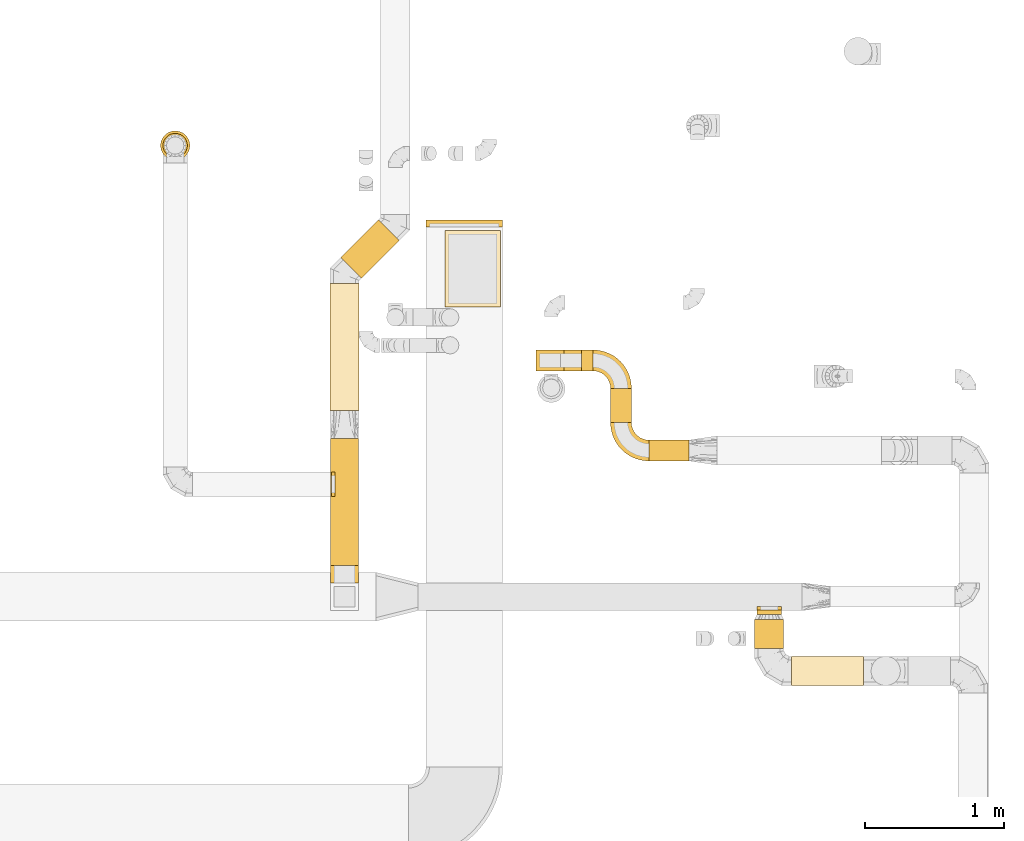
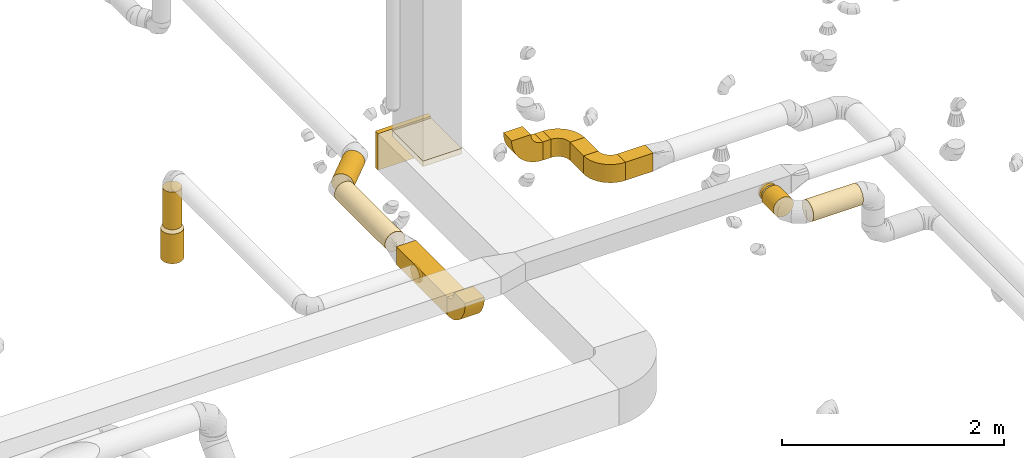
# One storey, part 9 of 97: 19 coverings.
"""IFC2X3 building model written with IfcOpenShell, lengths in millimetres."""

from ifc_helpers import new_model, entity, si_unit, converted_unit, derived_unit, direction, frame, frame_2d, origin, origin_2d_with_axis, place, context, subcontext, project, spatial, polyline, circle_curve, parameter, trimmed, segment, composite_curve, rectangle, circle, outline, extrude, element, save


model = new_model("IFC2X3")

# Units and contexts
model_context = context("Model", 3, precision=0.01, world=origin(), true_north=direction((6.12303176911189e-17, 1.0)))
body_context = subcontext(model_context, "Body", "Model", "MODEL_VIEW")
ifc_project = project(units=[si_unit("LENGTHUNIT", "METRE", prefix="MILLI"), si_unit("AREAUNIT", "SQUARE_METRE"), si_unit("VOLUMEUNIT", "CUBIC_METRE"), converted_unit("PLANEANGLEUNIT", "DEGREE", entity("IfcRatioMeasure", 0.0174532925199433), si_unit("PLANEANGLEUNIT", "RADIAN"), dimensions=[0, 0, 0, 0, 0, 0, 0]), si_unit("MASSUNIT", "GRAM", prefix="KILO"), derived_unit("MASSDENSITYUNIT", [(si_unit("MASSUNIT", "GRAM", prefix="KILO"), 1), (si_unit("LENGTHUNIT", "METRE"), -3)]), derived_unit("MOMENTOFINERTIAUNIT", [(si_unit("LENGTHUNIT", "METRE"), 4)]), si_unit("TIMEUNIT", "SECOND"), si_unit("FREQUENCYUNIT", "HERTZ"), si_unit("THERMODYNAMICTEMPERATUREUNIT", "DEGREE_CELSIUS"), derived_unit("THERMALTRANSMITTANCEUNIT", [(si_unit("MASSUNIT", "GRAM", prefix="KILO"), 1), (si_unit("THERMODYNAMICTEMPERATUREUNIT", "KELVIN"), -1), (si_unit("TIMEUNIT", "SECOND"), -3)]), derived_unit("VOLUMETRICFLOWRATEUNIT", [(si_unit("LENGTHUNIT", "METRE"), 3), (si_unit("TIMEUNIT", "SECOND"), -1)]), derived_unit("MASSFLOWRATEUNIT", [(si_unit("MASSUNIT", "GRAM", prefix="KILO"), 1), (si_unit("TIMEUNIT", "SECOND"), -1)]), derived_unit("ROTATIONALFREQUENCYUNIT", [(si_unit("TIMEUNIT", "SECOND"), -1)]), si_unit("ELECTRICCURRENTUNIT", "AMPERE"), si_unit("ELECTRICVOLTAGEUNIT", "VOLT"), si_unit("POWERUNIT", "WATT"), si_unit("FORCEUNIT", "NEWTON", prefix="KILO"), si_unit("ILLUMINANCEUNIT", "LUX"), si_unit("LUMINOUSFLUXUNIT", "LUMEN"), si_unit("LUMINOUSINTENSITYUNIT", "CANDELA"), derived_unit("USERDEFINED", [(si_unit("MASSUNIT", "GRAM", prefix="KILO"), -1), (si_unit("LENGTHUNIT", "METRE"), -2), (si_unit("TIMEUNIT", "SECOND"), 3), (si_unit("LUMINOUSFLUXUNIT", "LUMEN"), 1)]), derived_unit("LINEARVELOCITYUNIT", [(si_unit("LENGTHUNIT", "METRE"), 1), (si_unit("TIMEUNIT", "SECOND"), -1)]), si_unit("PRESSUREUNIT", "PASCAL"), derived_unit("USERDEFINED", [(si_unit("LENGTHUNIT", "METRE"), -2), (si_unit("MASSUNIT", "GRAM", prefix="KILO"), 1), (si_unit("TIMEUNIT", "SECOND"), -2)]), derived_unit("LINEARFORCEUNIT", [(si_unit("MASSUNIT", "GRAM", prefix="KILO"), 1), (si_unit("LENGTHUNIT", "METRE"), 1), (si_unit("TIMEUNIT", "SECOND"), -2), (si_unit("LENGTHUNIT", "METRE"), -1)]), derived_unit("PLANARFORCEUNIT", [(si_unit("MASSUNIT", "GRAM", prefix="KILO"), 1), (si_unit("LENGTHUNIT", "METRE"), 1), (si_unit("TIMEUNIT", "SECOND"), -2), (si_unit("LENGTHUNIT", "METRE"), -2)])], contexts=[model_context])

# Site, building, storey
site_placement = place(None, origin())
site = spatial("IfcSite", under=ifc_project, at=site_placement, CompositionType="ELEMENT")
building_placement = place(site_placement, origin())
building = spatial("IfcBuilding", under=site, at=building_placement, CompositionType="ELEMENT")
storey_placement = place(building_placement, frame((0.0, 0.0, -4900.0)))
storey = spatial("IfcBuildingStorey", under=building, at=storey_placement, CompositionType="ELEMENT", Elevation=-4900.0)

# Coverings
covering_1_placement = place(storey_placement, frame((67714.12, 12828.08, 3780.0)))
element("IfcCovering", 1, at=covering_1_placement, inside=storey, PredefinedType="INSULATION", context=body_context, shape_type="SweptSolid", body=[
    extrude(rectangle(XDim=50.0000000000016, YDim=549.999999999996, at=origin_2d_with_axis()), frame((275.0, 25.0, 0.0), z_axis=(0.0, 0.0, 1.0), x_axis=(0.0, -1.0, 0.0)), (0.0, 0.0, 1.0), 400.0),
])
covering_2_placement = place(storey_placement, frame((67849.81, 12253.05, 4119.01)))
element("IfcCovering", 2, at=covering_2_placement, inside=storey, PredefinedType="INSULATION", context=body_context, shape_type="SweptSolid", body=[
    extrude(rectangle(XDim=399.999999999996, YDim=550.000000000001, at=origin_2d_with_axis()), frame((200.0, 275.0, 0.0)), (0.0, 0.0, 1.0), 60.8775885811206),
])
covering_3_placement = place(storey_placement, frame((70088.14, 10045.77, 4260.9)))
element("IfcCovering", 3, at=covering_3_placement, inside=storey, PredefinedType="INSULATION", context=body_context, shape_type="SweptSolid", body=[
    extrude(circle(Radius=87.5, at=origin_2d_with_axis()), frame((89.1, 0.0, 89.1), z_axis=(0.0, 1.0, 0.0), x_axis=(-1.0, 0.0, 0.0)), (0.0, 0.0, 1.0), 33.2897157502389),
])
covering_4_placement = place(storey_placement, frame((70088.14, 10079.06, 4260.9)))
element("IfcCovering", 4, at=covering_4_placement, inside=storey, PredefinedType="INSULATION", context=body_context, shape_type="SweptSolid", body=[
    extrude(circle(Radius=87.5, at=origin_2d_with_axis()), frame((89.1, 0.0, 89.1), z_axis=(0.0, 1.0, 0.0), x_axis=(1.0, 0.0, 0.0)), (0.0, 0.0, 1.0), 26.0960000000116),
])
covering_5_placement = place(storey_placement, frame((70070.64, 9801.0, 4243.4)))
element("IfcCovering", 5, at=covering_5_placement, inside=storey, PredefinedType="INSULATION", context=body_context, shape_type="SweptSolid", body=[
    extrude(circle(Radius=105.0, at=origin_2d_with_axis()), frame((106.6, 0.0, 106.6), z_axis=(0.0, 1.0, 0.0), x_axis=(1.0, 0.0, 0.0)), (0.0, 0.0, 1.0), 209.769824249999),
])
covering_6_placement = place(storey_placement, frame((70337.23, 9534.41, 4243.4)))
element("IfcCovering", 6, at=covering_6_placement, inside=storey, PredefinedType="INSULATION", context=body_context, shape_type="SweptSolid", body=[
    extrude(circle(Radius=105.0, at=origin_2d_with_axis()), frame((0.0, 106.6, 106.6), z_axis=(1.0, 0.0, 0.0), x_axis=(0.0, 1.0, 0.0)), (0.0, 0.0, 1.0), 517.221330000017),
])
covering_7_placement = place(storey_placement, frame((67029.73, 10399.06, 3900.0)))
element("IfcCovering", 7, at=covering_7_placement, inside=storey, PredefinedType="INSULATION", context=body_context, shape_type="SweptSolid", body=[
    extrude(rectangle(XDim=912.000000000007, YDim=200.000000000007, at=origin_2d_with_axis()), frame((100.0, 456.0, 0.0), z_axis=(0.0, 0.0, 1.0), x_axis=(0.0, 1.0, 0.0)), (0.0, 0.0, 1.0), 200.0),
])
covering_8_placement = place(storey_placement, frame((67023.13, 11511.06, 3893.4)))
element("IfcCovering", 8, at=covering_8_placement, inside=storey, PredefinedType="INSULATION", context=body_context, shape_type="SweptSolid", body=[
    extrude(circle(Radius=105.0, at=origin_2d_with_axis()), frame((106.6, 0.0, 106.6), z_axis=(0.0, 1.0, 0.0), x_axis=(-1.0, 0.0, 0.0)), (0.0, 0.0, 1.0), 909.725830020307),
])
covering_9_placement = place(storey_placement, frame((67100.75, 12458.09, 3893.4)))
element("IfcCovering", 9, at=covering_9_placement, inside=storey, PredefinedType="INSULATION", context=body_context, shape_type="SweptSolid", body=[
    extrude(circle(Radius=105.0, at=origin_2d_with_axis()), frame((75.84, 75.84, 106.6), z_axis=(0.707106781186562, 0.707106781186533, 0.0), x_axis=(-0.707106781186533, 0.707106781186562, 0.0)), (0.0, 0.0, 1.0), 382.900697862583),
])
covering_10_placement = place(storey_placement, frame((67034.73, 10891.13, 3910.9)))
element("IfcCovering", 10, at=covering_10_placement, inside=storey, PredefinedType="INSULATION", context=body_context, shape_type="SweptSolid", body=[
    extrude(circle(Radius=87.5, at=origin_2d_with_axis()), frame((0.0, 89.1, 89.1), z_axis=(1.0, 0.0, 0.0), x_axis=(0.0, -1.0, 0.0)), (0.0, 0.0, 1.0), 26.0960000000159),
])
covering_11_placement = place(storey_placement, frame((65807.34, 13306.21, 3100.11)))
element("IfcCovering", 11, at=covering_11_placement, inside=storey, PredefinedType="INSULATION", context=body_context, shape_type="SweptSolid", body=[
    extrude(circle(Radius=105.0, at=origin_2d_with_axis()), frame((106.6, 106.6, 0.0), z_axis=(0.0, 0.0, 1.0), x_axis=(-1.0, 0.0, 0.0)), (0.0, 0.0, 1.0), 326.124652279636),
])
covering_12_placement = place(storey_placement, frame((65824.84, 13323.71, 3461.23)))
element("IfcCovering", 12, at=covering_12_placement, inside=storey, PredefinedType="INSULATION", context=body_context, shape_type="SweptSolid", body=[
    extrude(circle(Radius=87.5, at=origin_2d_with_axis()), frame((89.1, 89.1, 0.0), z_axis=(0.0, 0.0, 1.0), x_axis=(-1.0, 0.0, 0.0)), (0.0, 0.0, 1.0), 413.765350053108),
])
covering_13_placement = place(storey_placement, frame((69039.1, 11423.58, 4125.0)))
element("IfcCovering", 13, at=covering_13_placement, inside=storey, PredefinedType="INSULATION", context=body_context, shape_type="SweptSolid", body=[
    extrude(rectangle(XDim=246.447609999898, YDim=150.000000000001, at=origin_2d_with_axis()), frame((75.0, 123.22, 0.0), z_axis=(0.0, 0.0, 1.0), x_axis=(0.0, -1.0, 0.0)), (0.0, 0.0, 1.0), 200.0),
])
covering_14_placement = place(storey_placement, frame((68829.23, 11795.03, 4125.0)))
element("IfcCovering", 14, at=covering_14_placement, inside=storey, PredefinedType="INSULATION", context=body_context, shape_type="SweptSolid", body=[
    extrude(rectangle(XDim=84.8741199999927, YDim=150.000000000001, at=origin_2d_with_axis()), frame((42.44, 75.0, 0.0), z_axis=(0.0, 0.0, 1.0), x_axis=(-1.0, 0.0, 0.0)), (0.0, 0.0, 1.0), 200.0),
])
covering_15_placement = place(storey_placement, frame((69314.1, 11148.58, 4125.0)))
element("IfcCovering", 15, at=covering_15_placement, inside=storey, PredefinedType="INSULATION", context=body_context, shape_type="SweptSolid", body=[
    extrude(rectangle(XDim=287.766589999998, YDim=150.000000000001, at=origin_2d_with_axis()), frame((143.88, 75.0, 0.0)), (0.0, 0.0, 1.0), 200.0),
])
covering_16_placement = place(storey_placement, frame((67029.73, 10072.47, 3898.4)))
element("IfcCovering", 16, at=covering_16_placement, inside=storey, PredefinedType="INSULATION", context=body_context, shape_type="SweptSolid", body=[
    extrude(outline(composite_curve([segment(polyline([(12.5, -112.5), (212.5, -112.5)]), True, "CONTINUOUS"), segment(trimmed(circle_curve(frame_2d((-112.5, -112.5), x_axis=(0.0, 1.0)), 325.0), [parameter(270.0)], [parameter(0.0)], True, "PARAMETER"), True, "CONTINUOUS"), segment(polyline([(-112.5, 212.5), (-112.5, 12.5)]), True, "CONTINUOUS"), segment(trimmed(circle_curve(frame_2d((-112.5, -112.5), x_axis=(0.0, 1.0)), 125.0), [parameter(270.0)], [parameter(360.0)], True, "PARAMETER"), False, "CONTINUOUS")], self_intersect=False)), frame((0.0, 214.1, 214.1), z_axis=(1.0, 0.0, 0.0), x_axis=(0.0, -1.0, 0.0)), (0.0, 0.0, 1.0), 200.000000000007),
])
covering_17_placement = place(storey_placement, frame((68912.51, 11668.43, 4125.0)))
element("IfcCovering", 17, at=covering_17_placement, inside=storey, PredefinedType="INSULATION", context=body_context, shape_type="SweptSolid", body=[
    extrude(outline(composite_curve([segment(polyline([(-100.0, -25.0), (-100.0, -175.0)]), True, "CONTINUOUS"), segment(trimmed(circle_curve(frame_2d((-100.0, 100.0), x_axis=(1.0, 0.0)), 275.0), [parameter(270.0)], [parameter(0.0)], True, "PARAMETER"), True, "CONTINUOUS"), segment(polyline([(175.0, 100.0), (25.0, 100.0)]), True, "CONTINUOUS"), segment(trimmed(circle_curve(frame_2d((-100.0, 100.0), x_axis=(1.0, 0.0)), 125.0), [parameter(270.0)], [parameter(360.0)], True, "PARAMETER"), False, "CONTINUOUS")], self_intersect=False)), frame((101.6, 101.6, 0.0), z_axis=(0.0, 0.0, -1.0), x_axis=(1.0, 0.0, 0.0)), (0.0, 0.0, -1.0), 200.0),
])
covering_18_placement = place(storey_placement, frame((69037.51, 11146.98, 4125.0)))
element("IfcCovering", 18, at=covering_18_placement, inside=storey, PredefinedType="INSULATION", context=body_context, shape_type="SweptSolid", body=[
    extrude(outline(composite_curve([segment(polyline([(-100.0, -25.0), (-100.0, -175.0)]), True, "CONTINUOUS"), segment(trimmed(circle_curve(frame_2d((-100.0, 100.0), x_axis=(1.0, 0.0)), 275.0), [parameter(270.0)], [parameter(0.0)], True, "PARAMETER"), True, "CONTINUOUS"), segment(polyline([(175.0, 100.0), (25.0, 100.0)]), True, "CONTINUOUS"), segment(trimmed(circle_curve(frame_2d((-100.0, 100.0), x_axis=(1.0, 0.0)), 125.0), [parameter(270.0)], [parameter(360.0)], True, "PARAMETER"), False, "CONTINUOUS")], self_intersect=False)), frame((176.6, 176.6, 0.0), z_axis=(0.0, 0.0, -1.0), x_axis=(-1.0, 0.0, 0.0)), (0.0, 0.0, -1.0), 200.0),
])
covering_19_placement = place(storey_placement, frame((68502.63, 11795.03, 4123.4)))
element("IfcCovering", 19, at=covering_19_placement, inside=storey, PredefinedType="INSULATION", context=body_context, shape_type="SweptSolid", body=[
    extrude(outline(composite_curve([segment(polyline([(-112.5, -12.5), (-112.5, -212.5)]), True, "CONTINUOUS"), segment(trimmed(circle_curve(frame_2d((-112.5, 112.5), x_axis=(1.0, 0.0)), 325.0), [parameter(270.0)], [parameter(0.0)], True, "PARAMETER"), True, "CONTINUOUS"), segment(polyline([(212.5, 112.5), (12.5, 112.5)]), True, "CONTINUOUS"), segment(trimmed(circle_curve(frame_2d((-112.5, 112.5), x_axis=(1.0, 0.0)), 125.0), [parameter(270.0)], [parameter(360.0)], True, "PARAMETER"), False, "CONTINUOUS")], self_intersect=False)), frame((214.1, 0.0, 214.1), z_axis=(0.0, -1.0, 0.0), x_axis=(0.0, 0.0, -1.0)), (0.0, 0.0, -1.0), 150.000000000001),
])

save(model, "model.ifc")
